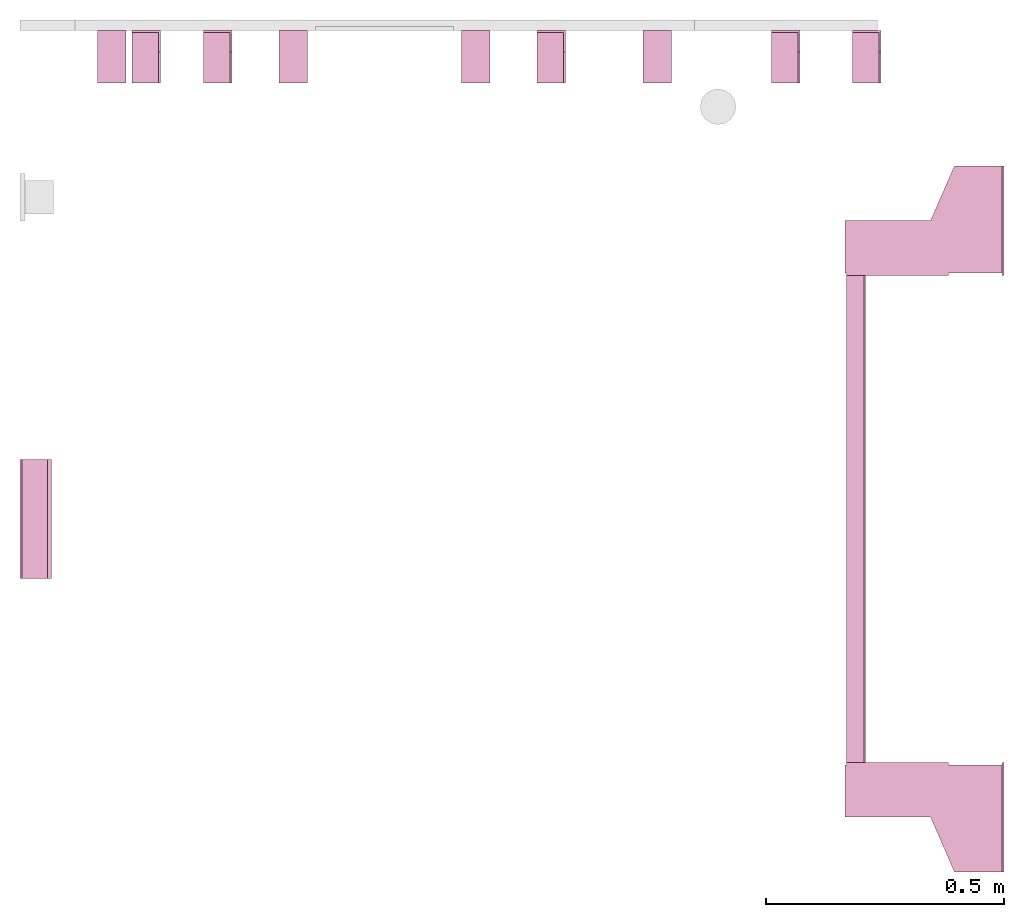
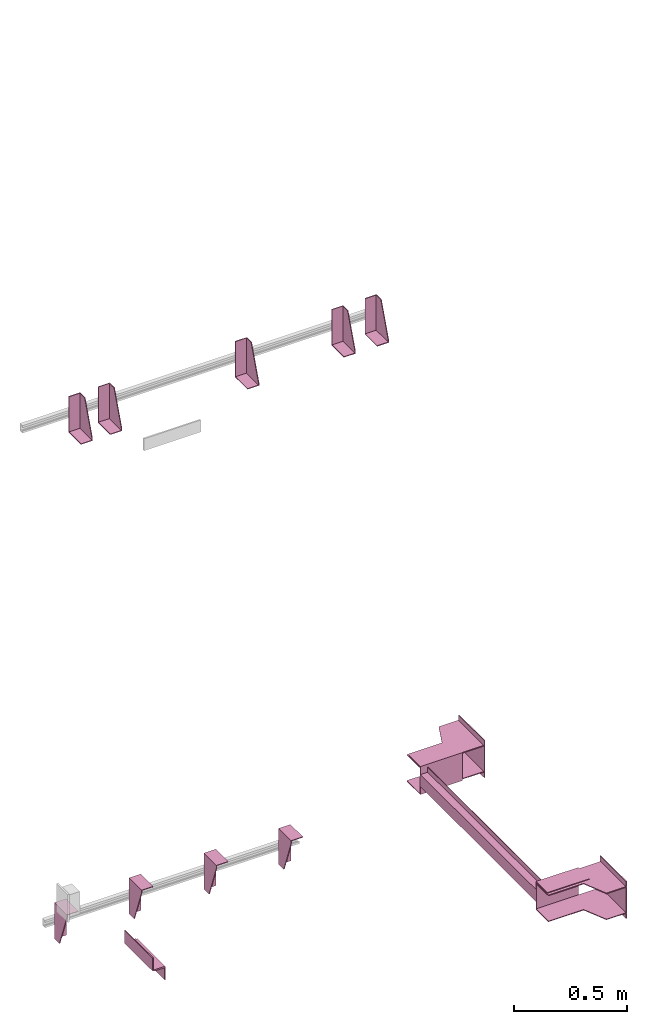
# One storey, part 3 of 3: 11 transport elements.
"""IFC4 building model written with IfcOpenShell, lengths in millimetres."""

from ifc_helpers import new_model, entity, si_unit, converted_unit, frame, origin_with_axes, place, context, subcontext, project, spatial, faceted_brep, element, save


model = new_model("IFC4")

# Units and contexts
context_of_model = context(None, 3, precision=0.01, world=origin_with_axes())
sub_context_1 = subcontext(context_of_model, None, None, "MODEL_VIEW")
sub_context_2 = subcontext(context_of_model, None, None, "MODEL_VIEW")
sub_context_3 = subcontext(context_of_model, None, None, "MODEL_VIEW")
sub_context_4 = subcontext(context_of_model, None, None, "MODEL_VIEW")
sub_context_5 = subcontext(context_of_model, None, None, "MODEL_VIEW")
sub_context_6 = subcontext(context_of_model, None, None, "MODEL_VIEW")
sub_context_7 = subcontext(context_of_model, None, None, "MODEL_VIEW")
sub_context_8 = subcontext(context_of_model, None, None, "MODEL_VIEW")
sub_context_9 = subcontext(context_of_model, None, None, "MODEL_VIEW")
sub_context_10 = subcontext(context_of_model, None, None, "MODEL_VIEW")
sub_context_11 = subcontext(context_of_model, None, None, "MODEL_VIEW")
ifc_project = project(units=[converted_unit("PLANEANGLEUNIT", "degree", entity("IfcPlaneAngleMeasure", 0.017453292519943), si_unit("PLANEANGLEUNIT", "RADIAN"), dimensions=[0, 0, 0, 0, 0, 0, 0]), si_unit("LENGTHUNIT", "METRE", prefix="MILLI"), si_unit("MASSUNIT", "GRAM", prefix="KILO"), converted_unit("TIMEUNIT", "year", entity("IfcTimeMeasure", 31557600.0), si_unit("TIMEUNIT", "SECOND"), dimensions=[0, 0, 1, 0, 0, 0, 0]), si_unit("THERMODYNAMICTEMPERATUREUNIT", "DEGREE_CELSIUS"), si_unit("AREAUNIT", "SQUARE_METRE"), si_unit("FORCEUNIT", "NEWTON"), si_unit("VOLUMEUNIT", "CUBIC_METRE"), si_unit("PRESSUREUNIT", "PASCAL"), si_unit("SOLIDANGLEUNIT", "STERADIAN")], contexts=[context_of_model])

# Site, building, storey
site = spatial("IfcSite", under=ifc_project)
building = spatial("IfcBuilding", under=site, Name="Document")
placement = place(None, origin_with_axes())
storey_placement = place(placement, frame((0.0, 0.0, -13090.0), z_axis=(0.0, 0.0, 1.0), x_axis=(1.0, 0.0, 0.0)))
storey = spatial("IfcBuildingStorey", under=building, at=storey_placement, Name="P3", Elevation=-13090.0)

# Transport elements
transport_element_1_placement = place(storey_placement, frame((2065.0, 1025.0, 390.0), z_axis=(0.0, 0.0, 1.0), x_axis=(0.0, 1.0, 0.0)))
element("IfcTransportElement", 1, at=transport_element_1_placement, inside=storey, PredefinedType="ELEVATOR", context=sub_context_1, shape_type="Brep", body=[
    faceted_brep([(-511.0, 331.0, 32.5), (511.0, 331.0, 32.5), (511.0, 331.0, -32.5), (-511.0, 331.0, -32.5), (511.0, 328.0, -29.5), (511.0, 328.0, 29.5), (-511.0, 328.0, 29.5), (-511.0, 328.0, -29.5), (511.0, 291.0, -32.5), (511.0, 291.0, -29.5), (-511.0, 291.0, -29.5), (-511.0, 291.0, -32.5), (511.0, 291.0, 29.5), (511.0, 291.0, 32.5), (-511.0, 291.0, 32.5), (-511.0, 291.0, 29.5)], [[[0, 1, 2, 3]], [[4, 5, 6, 7]], [[8, 9, 10, 11]], [[12, 13, 14, 15]], [[11, 10, 7, 6, 15, 14, 0, 3]], [[2, 1, 13, 12, 5, 4, 9, 8]], [[2, 8, 11, 3]], [[10, 9, 4, 7]], [[14, 13, 1, 0]], [[5, 12, 15, 6]]]),
    faceted_brep([(-611.0, 331.0, -72.5), (-514.0, 331.0, -72.5), (-514.0, 331.0, 72.5), (-611.0, 331.0, 72.5), (-611.0, 331.0, 75.5), (-511.0, 331.0, 75.5), (-511.0, 331.0, -75.5), (-611.0, 331.0, -75.5), (-511.0, 116.0, -75.5), (-511.0, 116.0, 75.5), (-611.0, 116.0, 75.5), (-611.0, 116.0, 72.5), (-514.0, 116.0, 72.5), (-514.0, 116.0, -72.5), (-611.0, 116.0, -72.5), (-611.0, 116.0, -75.5)], [[[0, 1, 2, 3, 4, 5, 6, 7]], [[8, 9, 10, 11, 12, 13, 14, 15]], [[15, 14, 0, 7]], [[13, 12, 2, 1]], [[5, 9, 8, 6]], [[11, 10, 4, 3]], [[6, 8, 15, 7]], [[14, 13, 1, 0]], [[2, 12, 11, 3]], [[10, 9, 5, 4]]]),
    faceted_brep([(511.0, 331.0, 75.5), (611.0, 331.0, 75.5), (611.0, 331.0, 72.5), (514.0, 331.0, 72.5), (514.0, 331.0, -72.5), (611.0, 331.0, -72.5), (611.0, 331.0, -75.5), (511.0, 331.0, -75.5), (511.0, 116.0, -75.5), (611.0, 116.0, -75.5), (611.0, 116.0, -72.5), (514.0, 116.0, -72.5), (514.0, 116.0, 72.5), (611.0, 116.0, 72.5), (611.0, 116.0, 75.5), (511.0, 116.0, 75.5)], [[[0, 1, 2, 3, 4, 5, 6, 7]], [[8, 9, 10, 11, 12, 13, 14, 15]], [[8, 15, 0, 7]], [[3, 12, 11, 4]], [[5, 10, 9, 6]], [[1, 14, 13, 2]], [[6, 9, 8, 7]], [[11, 10, 5, 4]], [[15, 14, 1, 0]], [[2, 13, 12, 3]]]),
    faceted_brep([(-511.0, 291.0, 59.5), (-511.0, 294.0, 59.5), (-511.0, 294.0, 32.5), (-511.0, 291.0, 32.5), (511.0, 291.0, 59.5), (511.0, 291.0, 32.5), (511.0, 294.0, 32.5), (511.0, 294.0, 59.5)], [[[0, 1, 2, 3]], [[4, 5, 6, 7]], [[0, 3, 5, 4]], [[3, 2, 6, 5]], [[2, 1, 7, 6]], [[1, 0, 4, 7]]]),
    faceted_brep([(-511.0, 291.0, -32.5), (-511.0, 294.0, -32.5), (-511.0, 294.0, -59.5), (-511.0, 291.0, -59.5), (511.0, 291.0, -32.5), (511.0, 291.0, -59.5), (511.0, 294.0, -59.5), (511.0, 294.0, -32.5)], [[[0, 1, 2, 3]], [[4, 5, 6, 7]], [[0, 3, 5, 4]], [[3, 2, 6, 5]], [[2, 1, 7, 6]], [[1, 0, 4, 7]]]),
    faceted_brep([(-626.0, 334.0, -68.5), (-516.0, 334.0, -68.5), (-516.0, 334.0, -72.5), (-626.0, 334.0, -72.5), (-516.0, 4.0, -72.5), (-516.0, 4.0, -68.5), (-741.0, 4.0, -68.5), (-741.0, 4.0, -72.5), (-741.0, 104.0, -68.5), (-626.0, 154.0, -68.5), (-626.0, 154.0, -72.5), (-741.0, 104.0, -72.5)], [[[0, 1, 2, 3]], [[4, 5, 6, 7]], [[8, 9, 10, 11]], [[10, 9, 0, 3]], [[1, 5, 4, 2]], [[7, 6, 8, 11]], [[2, 4, 7, 11, 10, 3]], [[9, 8, 6, 5, 1, 0]]]),
    faceted_brep([(516.0, 334.0, 72.5), (626.0, 334.0, 72.5), (626.0, 334.0, 68.5), (516.0, 334.0, 68.5), (741.0, 4.0, 68.5), (741.0, 4.0, 72.5), (516.0, 4.0, 72.5), (516.0, 4.0, 68.5), (626.0, 154.0, 72.5), (741.0, 104.0, 72.5), (741.0, 104.0, 68.5), (626.0, 154.0, 68.5)], [[[0, 1, 2, 3]], [[4, 5, 6, 7]], [[8, 9, 10, 11]], [[7, 6, 0, 3]], [[1, 8, 11, 2]], [[9, 5, 4, 10]], [[2, 11, 10, 4, 7, 3]], [[6, 5, 9, 8, 1, 0]]]),
    faceted_brep([(-626.0, 334.0, 72.5), (-516.0, 334.0, 72.5), (-516.0, 334.0, 68.5), (-626.0, 334.0, 68.5), (-516.0, 4.0, 68.5), (-516.0, 4.0, 72.5), (-741.0, 4.0, 72.5), (-741.0, 4.0, 68.5), (-741.0, 104.0, 72.5), (-626.0, 154.0, 72.5), (-626.0, 154.0, 68.5), (-741.0, 104.0, 68.5)], [[[0, 1, 2, 3]], [[4, 5, 6, 7]], [[8, 9, 10, 11]], [[10, 9, 0, 3]], [[1, 5, 4, 2]], [[7, 6, 8, 11]], [[2, 4, 7, 11, 10, 3]], [[9, 8, 6, 5, 1, 0]]]),
    faceted_brep([(516.0, 334.0, -68.5), (626.0, 334.0, -68.5), (626.0, 334.0, -72.5), (516.0, 334.0, -72.5), (741.0, 4.0, -72.5), (741.0, 4.0, -68.5), (516.0, 4.0, -68.5), (516.0, 4.0, -72.5), (626.0, 154.0, -68.5), (741.0, 104.0, -68.5), (741.0, 104.0, -72.5), (626.0, 154.0, -72.5)], [[[0, 1, 2, 3]], [[4, 5, 6, 7]], [[8, 9, 10, 11]], [[7, 6, 0, 3]], [[1, 8, 11, 2]], [[9, 5, 4, 10]], [[2, 11, 10, 4, 7, 3]], [[6, 5, 9, 8, 1, 0]]]),
    faceted_brep([(741.0, 0.0, -100.0), (741.0, 0.0, 100.0), (511.0, 0.0, 100.0), (511.0, 0.0, -100.0), (741.0, 4.0, -100.0), (511.0, 4.0, -100.0), (511.0, 4.0, 100.0), (741.0, 4.0, 100.0)], [[[0, 1, 2, 3]], [[4, 5, 6, 7]], [[0, 3, 5, 4]], [[3, 2, 6, 5]], [[2, 1, 7, 6]], [[1, 0, 4, 7]]]),
    faceted_brep([(-511.0, 0.0, -100.0), (-511.0, 0.0, 100.0), (-741.0, 0.0, 100.0), (-741.0, 0.0, -100.0), (-511.0, 4.0, -100.0), (-741.0, 4.0, -100.0), (-741.0, 4.0, 100.0), (-511.0, 4.0, 100.0)], [[[0, 1, 2, 3]], [[4, 5, 6, 7]], [[0, 3, 5, 4]], [[3, 2, 6, 5]], [[2, 1, 7, 6]], [[1, 0, 4, 7]]]),
])
transport_element_2_placement = place(storey_placement, frame((1777.0, 2050.0, 2580.0), z_axis=(0.0, 0.0, 1.0), x_axis=(-1.0, 0.0, 0.0)))
element("IfcTransportElement", 2, at=transport_element_2_placement, inside=storey, PredefinedType="ELEVATOR", context=sub_context_2, shape_type="Brep", body=[
    faceted_brep([(-30.0, 4.0, -93.0), (-30.0, 4.0, 97.0), (-30.0, 45.0, 97.0), (-30.0, 110.0, -82.0), (-30.0, 110.0, -93.0), (-26.0, 4.0, -93.0), (-26.0, 110.0, -93.0), (-26.0, 110.0, -82.0), (-26.0, 45.0, 97.0), (-26.0, 4.0, 97.0)], [[[0, 1, 2, 3, 4]], [[5, 6, 7, 8, 9]], [[5, 0, 4, 6]], [[6, 4, 3, 7]], [[7, 3, 2, 8]], [[8, 2, 1, 9]], [[9, 1, 0, 5]]]),
    faceted_brep([(30.0, 110.0, -93.0), (30.0, 4.0, -93.0), (30.0, 4.0, 97.0), (30.0, 0.0, 97.0), (30.0, 0.0, -97.0), (30.0, 110.0, -97.0), (-30.0, 0.0, -97.0), (-30.0, 0.0, 97.0), (-30.0, 4.0, 97.0), (-30.0, 4.0, -93.0), (-30.0, 110.0, -93.0), (-30.0, 110.0, -97.0)], [[[0, 1, 2, 3, 4, 5]], [[6, 7, 8, 9, 10, 11]], [[11, 10, 0, 5]], [[9, 8, 2, 1]], [[3, 7, 6, 4]], [[4, 6, 11, 5]], [[10, 9, 1, 0]], [[8, 7, 3, 2]]]),
])
transport_element_3_placement = place(storey_placement, frame((1607.0, 2050.0, 2580.0), z_axis=(0.0, 0.0, 1.0), x_axis=(-1.0, 0.0, 0.0)))
element("IfcTransportElement", 3, at=transport_element_3_placement, inside=storey, PredefinedType="ELEVATOR", context=sub_context_3, shape_type="Brep", body=[
    faceted_brep([(30.0, 110.0, -93.0), (30.0, 4.0, -93.0), (30.0, 4.0, 97.0), (30.0, 0.0, 97.0), (30.0, 0.0, -97.0), (30.0, 110.0, -97.0), (-30.0, 0.0, -97.0), (-30.0, 0.0, 97.0), (-30.0, 4.0, 97.0), (-30.0, 4.0, -93.0), (-30.0, 110.0, -93.0), (-30.0, 110.0, -97.0)], [[[0, 1, 2, 3, 4, 5]], [[6, 7, 8, 9, 10, 11]], [[11, 10, 0, 5]], [[9, 8, 2, 1]], [[3, 7, 6, 4]], [[4, 6, 11, 5]], [[10, 9, 1, 0]], [[8, 7, 3, 2]]]),
    faceted_brep([(-30.0, 4.0, -93.0), (-30.0, 4.0, 97.0), (-30.0, 45.0, 97.0), (-30.0, 110.0, -82.0), (-30.0, 110.0, -93.0), (-26.0, 4.0, -93.0), (-26.0, 110.0, -93.0), (-26.0, 110.0, -82.0), (-26.0, 45.0, 97.0), (-26.0, 4.0, 97.0)], [[[0, 1, 2, 3, 4]], [[5, 6, 7, 8, 9]], [[5, 0, 4, 6]], [[6, 4, 3, 7]], [[7, 3, 2, 8]], [[8, 2, 1, 9]], [[9, 1, 0, 5]]]),
])
transport_element_4_placement = place(storey_placement, frame((1115.0, 2050.0, 2580.0), z_axis=(0.0, 0.0, 1.0), x_axis=(-1.0, 0.0, 0.0)))
element("IfcTransportElement", 4, at=transport_element_4_placement, inside=storey, PredefinedType="ELEVATOR", context=sub_context_4, shape_type="Brep", body=[
    faceted_brep([(-30.0, 4.0, -93.0), (-30.0, 4.0, 97.0), (-30.0, 45.0, 97.0), (-30.0, 110.0, -82.0), (-30.0, 110.0, -93.0), (-26.0, 4.0, -93.0), (-26.0, 110.0, -93.0), (-26.0, 110.0, -82.0), (-26.0, 45.0, 97.0), (-26.0, 4.0, 97.0)], [[[0, 1, 2, 3, 4]], [[5, 6, 7, 8, 9]], [[5, 0, 4, 6]], [[6, 4, 3, 7]], [[7, 3, 2, 8]], [[8, 2, 1, 9]], [[9, 1, 0, 5]]]),
    faceted_brep([(30.0, 110.0, -93.0), (30.0, 4.0, -93.0), (30.0, 4.0, 97.0), (30.0, 0.0, 97.0), (30.0, 0.0, -97.0), (30.0, 110.0, -97.0), (-30.0, 0.0, -97.0), (-30.0, 0.0, 97.0), (-30.0, 4.0, 97.0), (-30.0, 4.0, -93.0), (-30.0, 110.0, -93.0), (-30.0, 110.0, -97.0)], [[[0, 1, 2, 3, 4, 5]], [[6, 7, 8, 9, 10, 11]], [[11, 10, 0, 5]], [[9, 8, 2, 1]], [[3, 7, 6, 4]], [[4, 6, 11, 5]], [[10, 9, 1, 0]], [[8, 7, 3, 2]]]),
])
transport_element_5_placement = place(storey_placement, frame((415.0, 2050.0, 2580.0), z_axis=(0.0, 0.0, 1.0), x_axis=(-1.0, 0.0, 0.0)))
element("IfcTransportElement", 5, at=transport_element_5_placement, inside=storey, PredefinedType="ELEVATOR", context=sub_context_5, shape_type="Brep", body=[
    faceted_brep([(-30.0, 4.0, -93.0), (-30.0, 4.0, 97.0), (-30.0, 45.0, 97.0), (-30.0, 110.0, -82.0), (-30.0, 110.0, -93.0), (-26.0, 4.0, -93.0), (-26.0, 110.0, -93.0), (-26.0, 110.0, -82.0), (-26.0, 45.0, 97.0), (-26.0, 4.0, 97.0)], [[[0, 1, 2, 3, 4]], [[5, 6, 7, 8, 9]], [[5, 0, 4, 6]], [[6, 4, 3, 7]], [[7, 3, 2, 8]], [[8, 2, 1, 9]], [[9, 1, 0, 5]]]),
    faceted_brep([(30.0, 110.0, -93.0), (30.0, 4.0, -93.0), (30.0, 4.0, 97.0), (30.0, 0.0, 97.0), (30.0, 0.0, -97.0), (30.0, 110.0, -97.0), (-30.0, 0.0, -97.0), (-30.0, 0.0, 97.0), (-30.0, 4.0, 97.0), (-30.0, 4.0, -93.0), (-30.0, 110.0, -93.0), (-30.0, 110.0, -97.0)], [[[0, 1, 2, 3, 4, 5]], [[6, 7, 8, 9, 10, 11]], [[11, 10, 0, 5]], [[9, 8, 2, 1]], [[3, 7, 6, 4]], [[4, 6, 11, 5]], [[10, 9, 1, 0]], [[8, 7, 3, 2]]]),
])
transport_element_6_placement = place(storey_placement, frame((265.0, 2050.0, 2580.0), z_axis=(0.0, 0.0, 1.0), x_axis=(-1.0, 0.0, 0.0)))
element("IfcTransportElement", 6, at=transport_element_6_placement, inside=storey, PredefinedType="ELEVATOR", context=sub_context_6, shape_type="Brep", body=[
    faceted_brep([(-30.0, 4.0, -93.0), (-30.0, 4.0, 97.0), (-30.0, 45.0, 97.0), (-30.0, 110.0, -82.0), (-30.0, 110.0, -93.0), (-26.0, 4.0, -93.0), (-26.0, 110.0, -93.0), (-26.0, 110.0, -82.0), (-26.0, 45.0, 97.0), (-26.0, 4.0, 97.0)], [[[0, 1, 2, 3, 4]], [[5, 6, 7, 8, 9]], [[5, 0, 4, 6]], [[6, 4, 3, 7]], [[7, 3, 2, 8]], [[8, 2, 1, 9]], [[9, 1, 0, 5]]]),
    faceted_brep([(30.0, 110.0, -93.0), (30.0, 4.0, -93.0), (30.0, 4.0, 97.0), (30.0, 0.0, 97.0), (30.0, 0.0, -97.0), (30.0, 110.0, -97.0), (-30.0, 0.0, -97.0), (-30.0, 0.0, 97.0), (-30.0, 4.0, 97.0), (-30.0, 4.0, -93.0), (-30.0, 110.0, -93.0), (-30.0, 110.0, -97.0)], [[[0, 1, 2, 3, 4, 5]], [[6, 7, 8, 9, 10, 11]], [[11, 10, 0, 5]], [[9, 8, 2, 1]], [[3, 7, 6, 4]], [[4, 6, 11, 5]], [[10, 9, 1, 0]], [[8, 7, 3, 2]]]),
])
transport_element_7_placement = place(storey_placement, frame((192.5, 2050.0, -30.0), z_axis=(0.0, 0.0, -1.0), x_axis=(1.0, 0.0, 0.0)))
element("IfcTransportElement", 7, at=transport_element_7_placement, inside=storey, PredefinedType="ELEVATOR", context=sub_context_7, shape_type="Brep", body=[
    faceted_brep([(-30.0, 4.0, 4.0), (-30.0, 110.0, 4.0), (-30.0, 110.0, 0.0), (-30.0, 0.0, 0.0), (-30.0, 0.0, 194.0), (-30.0, 4.0, 194.0), (30.0, 0.0, 194.0), (30.0, 0.0, 0.0), (30.0, 110.0, 0.0), (30.0, 110.0, 4.0), (30.0, 4.0, 4.0), (30.0, 4.0, 194.0)], [[[0, 1, 2, 3, 4, 5]], [[6, 7, 8, 9, 10, 11]], [[11, 10, 0, 5]], [[3, 7, 6, 4]], [[9, 8, 2, 1]], [[4, 6, 11, 5]], [[0, 10, 9, 1]], [[8, 7, 3, 2]]]),
    faceted_brep([(-30.0, 4.0, 4.0), (-30.0, 4.0, 194.0), (-30.0, 45.0, 194.0), (-30.0, 110.0, 15.0), (-30.0, 110.0, 4.0), (-26.0, 4.0, 4.0), (-26.0, 110.0, 4.0), (-26.0, 110.0, 15.0), (-26.0, 45.0, 194.0), (-26.0, 4.0, 194.0)], [[[0, 1, 2, 3, 4]], [[5, 6, 7, 8, 9]], [[5, 0, 4, 6]], [[6, 4, 3, 7]], [[7, 3, 2, 8]], [[8, 2, 1, 9]], [[9, 1, 0, 5]]]),
])
transport_element_8_placement = place(storey_placement, frame((573.84, 2050.0, -30.0), z_axis=(0.0, 0.0, -1.0), x_axis=(1.0, 0.0, 0.0)))
element("IfcTransportElement", 8, at=transport_element_8_placement, inside=storey, PredefinedType="ELEVATOR", context=sub_context_8, shape_type="Brep", body=[
    faceted_brep([(-29.999973144531282, 4.0, 4.0), (-29.999973144531282, 4.0, 194.0), (-29.999973144531282, 45.0, 194.0), (-29.999973144531282, 110.0, 15.0), (-29.999973144531282, 110.0, 4.0), (-25.999973144531282, 4.0, 4.0), (-25.999973144531282, 110.0, 4.0), (-25.999973144531282, 110.0, 15.0), (-25.999973144531282, 45.0, 194.0), (-25.999973144531282, 4.0, 194.0)], [[[0, 1, 2, 3, 4]], [[5, 6, 7, 8, 9]], [[5, 0, 4, 6]], [[6, 4, 3, 7]], [[7, 3, 2, 8]], [[8, 2, 1, 9]], [[9, 1, 0, 5]]]),
    faceted_brep([(-29.999973144531282, 4.0, 4.0), (-29.999973144531282, 110.0, 4.0), (-29.999973144531282, 110.0, 0.0), (-29.999973144531282, 0.0, 0.0), (-29.999973144531282, 0.0, 194.0), (-29.999973144531282, 4.0, 194.0), (30.000026855468718, 0.0, 194.0), (30.000026855468718, 0.0, 0.0), (30.000026855468718, 110.0, 0.0), (30.000026855468718, 110.0, 4.0), (30.000026855468718, 4.0, 4.0), (30.000026855468718, 4.0, 194.0)], [[[0, 1, 2, 3, 4, 5]], [[6, 7, 8, 9, 10, 11]], [[11, 10, 0, 5]], [[3, 7, 6, 4]], [[9, 8, 2, 1]], [[4, 6, 11, 5]], [[0, 10, 9, 1]], [[8, 7, 3, 2]]]),
])
transport_element_9_placement = place(storey_placement, frame((956.16, 2050.0, -30.0), z_axis=(0.0, 0.0, -1.0), x_axis=(1.0, 0.0, 0.0)))
element("IfcTransportElement", 9, at=transport_element_9_placement, inside=storey, PredefinedType="ELEVATOR", context=sub_context_9, shape_type="Brep", body=[
    faceted_brep([(-30.000026855468718, 4.0, 4.0), (-30.000026855468718, 110.0, 4.0), (-30.000026855468718, 110.0, 0.0), (-30.000026855468718, 0.0, 0.0), (-30.000026855468718, 0.0, 194.0), (-30.000026855468718, 4.0, 194.0), (29.999973144531282, 0.0, 194.0), (29.999973144531282, 0.0, 0.0), (29.999973144531282, 110.0, 0.0), (29.999973144531282, 110.0, 4.0), (29.999973144531282, 4.0, 4.0), (29.999973144531282, 4.0, 194.0)], [[[0, 1, 2, 3, 4, 5]], [[6, 7, 8, 9, 10, 11]], [[11, 10, 0, 5]], [[3, 7, 6, 4]], [[9, 8, 2, 1]], [[4, 6, 11, 5]], [[0, 10, 9, 1]], [[8, 7, 3, 2]]]),
    faceted_brep([(-30.000026855468718, 4.0, 4.0), (-30.000026855468718, 4.0, 194.0), (-30.000026855468718, 45.0, 194.0), (-30.000026855468718, 110.0, 15.0), (-30.000026855468718, 110.0, 4.0), (-26.000026855468718, 4.0, 4.0), (-26.000026855468718, 110.0, 4.0), (-26.000026855468718, 110.0, 15.0), (-26.000026855468718, 45.0, 194.0), (-26.000026855468718, 4.0, 194.0)], [[[0, 1, 2, 3, 4]], [[5, 6, 7, 8, 9]], [[5, 0, 4, 6]], [[6, 4, 3, 7]], [[7, 3, 2, 8]], [[8, 2, 1, 9]], [[9, 1, 0, 5]]]),
])
transport_element_10_placement = place(storey_placement, frame((1337.5, 2050.0, -30.0), z_axis=(0.0, 0.0, -1.0), x_axis=(1.0, 0.0, 0.0)))
element("IfcTransportElement", 10, at=transport_element_10_placement, inside=storey, PredefinedType="ELEVATOR", context=sub_context_10, shape_type="Brep", body=[
    faceted_brep([(-30.0, 4.0, 4.0), (-30.0, 4.0, 194.0), (-30.0, 45.0, 194.0), (-30.0, 110.0, 15.0), (-30.0, 110.0, 4.0), (-26.0, 4.0, 4.0), (-26.0, 110.0, 4.0), (-26.0, 110.0, 15.0), (-26.0, 45.0, 194.0), (-26.0, 4.0, 194.0)], [[[0, 1, 2, 3, 4]], [[5, 6, 7, 8, 9]], [[5, 0, 4, 6]], [[6, 4, 3, 7]], [[7, 3, 2, 8]], [[8, 2, 1, 9]], [[9, 1, 0, 5]]]),
    faceted_brep([(-30.0, 4.0, 4.0), (-30.0, 110.0, 4.0), (-30.0, 110.0, 0.0), (-30.0, 0.0, 0.0), (-30.0, 0.0, 194.0), (-30.0, 4.0, 194.0), (30.0, 0.0, 194.0), (30.0, 0.0, 0.0), (30.0, 110.0, 0.0), (30.0, 110.0, 4.0), (30.0, 4.0, 4.0), (30.0, 4.0, 194.0)], [[[0, 1, 2, 3, 4, 5]], [[6, 7, 8, 9, 10, 11]], [[11, 10, 0, 5]], [[3, 7, 6, 4]], [[9, 8, 2, 1]], [[4, 6, 11, 5]], [[0, 10, 9, 1]], [[8, 7, 3, 2]]]),
])
transport_element_11_placement = place(storey_placement, frame((0.0, 1025.0, 390.0), z_axis=(0.0, 0.0, 1.0), x_axis=(0.0, -1.0, 0.0)))
element("IfcTransportElement", 11, at=transport_element_11_placement, inside=storey, PredefinedType="ELEVATOR", context=sub_context_11, shape_type="Brep", body=[
    faceted_brep([(125.0, 8.0, -35.0), (-125.0, 8.0, -35.0), (-125.0, 8.0, -39.0), (125.0, 8.0, -39.0), (125.0, 62.0, -39.0), (-125.0, 62.0, -39.0), (-125.0, 62.0, -105.0), (125.0, 62.0, -105.0), (-125.0, 66.0, -105.0), (-125.0, 66.0, -35.0), (125.0, 66.0, -35.0), (125.0, 66.0, -105.0)], [[[0, 1, 2, 3]], [[4, 5, 6, 7]], [[8, 9, 10, 11]], [[4, 7, 11, 10, 0, 3]], [[1, 9, 8, 6, 5, 2]], [[2, 5, 4, 3]], [[10, 9, 1, 0]], [[6, 8, 11, 7]]]),
    faceted_brep([(125.0, 0.0, 35.0), (-125.0, 0.0, 35.0), (-125.0, 0.0, -35.0), (125.0, 0.0, -35.0), (-125.0, 4.0, -31.0), (-125.0, 4.0, 35.0), (125.0, 4.0, 35.0), (125.0, 4.0, -31.0), (-125.0, 58.0, -35.0), (-125.0, 58.0, -31.0), (125.0, 58.0, -31.0), (125.0, 58.0, -35.0)], [[[0, 1, 2, 3]], [[4, 5, 6, 7]], [[8, 9, 10, 11]], [[11, 10, 7, 6, 0, 3]], [[2, 1, 5, 4, 9, 8]], [[2, 8, 11, 3]], [[10, 9, 4, 7]], [[6, 5, 1, 0]]]),
])

save(model, "model.ifc")
